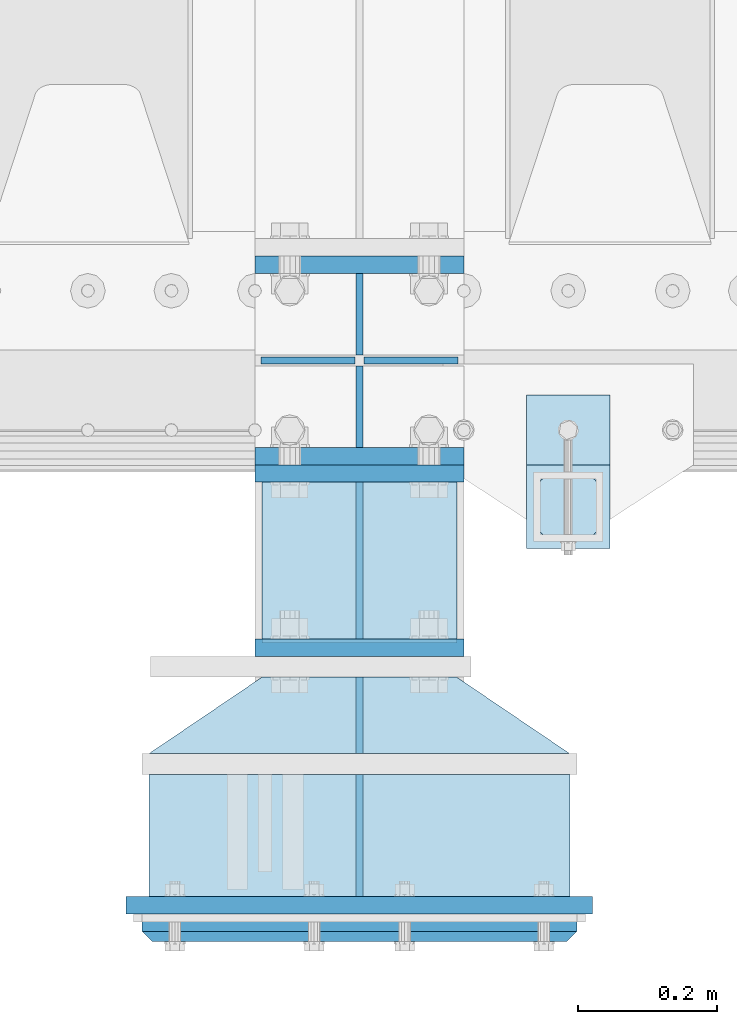
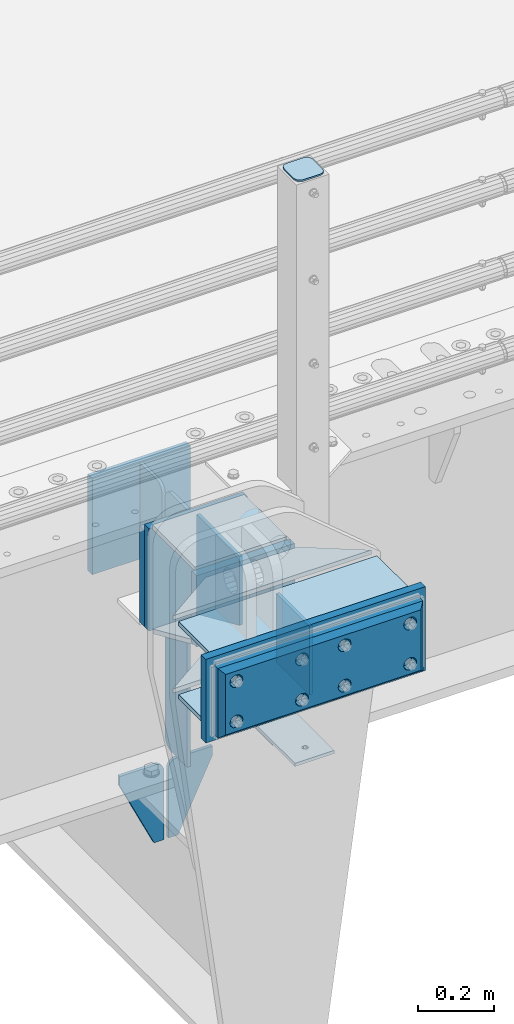
# One storey, part 182 of 219: 23 plates.
"""IFC2X3 building model written with IfcOpenShell, lengths in millimetres."""

from ifc_helpers import new_model, si_unit, frame, origin_with_axes, place, context, subcontext, project, spatial, faceted_brep, material, type_object, element, save


model = new_model("IFC2X3")

# Units and contexts
model_context = context("Model", 3, precision=1e-05, world=origin_with_axes())
body_context = subcontext(model_context, "Body", "Model", "MODEL_VIEW")
ifc_project = project(units=[si_unit("LENGTHUNIT", "METRE", prefix="MILLI"), si_unit("AREAUNIT", "SQUARE_METRE"), si_unit("VOLUMEUNIT", "CUBIC_METRE"), si_unit("MASSUNIT", "GRAM", prefix="KILO"), si_unit("TIMEUNIT", "SECOND"), si_unit("PLANEANGLEUNIT", "RADIAN"), si_unit("SOLIDANGLEUNIT", "STERADIAN"), si_unit("THERMODYNAMICTEMPERATUREUNIT", "DEGREE_CELSIUS"), si_unit("LUMINOUSINTENSITYUNIT", "LUMEN")], contexts=[model_context])

# Site, building, storey
site_placement = place(None, origin_with_axes())
site = spatial("IfcSite", under=ifc_project, at=site_placement, CompositionType="ELEMENT")
building_placement = place(site_placement, origin_with_axes())
building = spatial("IfcBuilding", under=site, at=building_placement, Name="Standard", CompositionType="ELEMENT")
storey_placement = place(building_placement, origin_with_axes())
storey = spatial("IfcBuildingStorey", under=building, at=storey_placement, Name="Undefined", CompositionType="ELEMENT", Elevation=0.0)

# Plates
ifc_material_1 = material(Name="STEEL/S355N")
plate_type_1 = type_object("IfcPlateType", PredefinedType="NOTDEFINED")
plate_1_placement = place(storey_placement, frame((10240.0000000204, 23837.500000015, -340.000018206199), z_axis=(0.0, 0.0, 1.0), x_axis=(1.0, 0.0, 0.0)))
element("IfcPlate", 1, at=plate_1_placement, inside=storey, type_object=plate_type_1, material=ifc_material_1, context=body_context, shape_type="Brep", body=[
    faceted_brep([(0.0, -12.5, 0.0), (0.0, -12.5, 330.0), (0.0, 12.5, 330.0), (0.0, 12.5, 0.0), (300.0, -12.5, 330.0), (300.0, 12.5, 330.0), (300.0, -12.5, 0.0), (300.0, 12.5, 0.0)], [[[0, 1, 2, 3]], [[1, 4, 5, 2]], [[4, 6, 7, 5]], [[6, 0, 3, 7]], [[5, 7, 3, 2]], [[6, 4, 1, 0]]]),
])
for number, where, z_axis, x_axis in (
    (2, (10240.0, 24137.5, -340.0), (0.0, 0.0, 1.0), (1.0, 0.0, 0.0)),
    (3, (10240.0, 23862.5, -340.0), (0.0, 0.0, 1.0), (1.0, 0.0, 0.0)),
):
    element("IfcPlate", number, at=place(storey_placement, frame(where, z_axis=z_axis, x_axis=x_axis)), inside=storey, type_object=plate_type_1, material=ifc_material_1, context=body_context, shape_type="Brep", body=[
        faceted_brep([(0.0, -12.5, 0.0), (0.0, -12.5, 310.0), (0.0, 12.5, 310.0), (0.0, 12.5, 0.0), (300.0, -12.5, 310.0), (300.0, 12.5, 310.0), (300.0, -12.5, 0.0), (300.0, 12.5, 0.0)], [[[0, 1, 2, 3]], [[1, 4, 5, 2]], [[4, 6, 7, 5]], [[6, 0, 3, 7]], [[5, 7, 3, 2]], [[6, 4, 1, 0]]]),
    ])
plate_type_2 = type_object("IfcPlateType", PredefinedType="NOTDEFINED")
plate_2_placement = place(storey_placement, frame((10390.0000000208, 23825.0000000149, -336.000018206199), z_axis=(0.0, -1.0, 0.0), x_axis=(0.0, 0.0, 1.0)))
element("IfcPlate", 4, at=plate_2_placement, inside=storey, type_object=plate_type_2, material=ifc_material_1, context=body_context, shape_type="Brep", body=[
    faceted_brep([(0.0, -5.0, 0.0), (100.0, -5.0, 225.0), (100.0, 5.0, 225.0), (0.0, 5.0, 0.0), (322.0, -5.0, 225.0), (322.0, 5.0, 225.0), (322.0, -5.0, 0.0), (322.0, 5.0, 0.0)], [[[0, 1, 2, 3]], [[1, 4, 5, 2]], [[4, 6, 7, 5]], [[6, 0, 3, 7]], [[5, 7, 3, 2]], [[6, 4, 1, 0]]]),
])
plate_type_3 = type_object("IfcPlateType", PredefinedType="NOTDEFINED")
for number, where, z_axis, x_axis in (
    (5, (10390.0, 24008.0, -30.0), (0.0, 0.0, -1.0), (0.0, 1.0, 0.0)),
    (6, (10390.0, 23992.0, -30.0), (0.0, 0.0, -1.0), (0.0, -1.0, 0.0)),
):
    element("IfcPlate", number, at=place(storey_placement, frame(where, z_axis=z_axis, x_axis=x_axis)), inside=storey, type_object=plate_type_3, material=ifc_material_1, context=body_context, shape_type="Brep", body=[
        faceted_brep([(0.0, -5.0, 30.0), (0.0, -5.0, 306.0), (0.0, 5.0, 306.0), (0.0, 5.0, 30.0), (117.0, -5.0, 306.0), (117.0, 5.0, 306.0), (117.0, -5.0, 0.0), (117.0, 5.0, 0.0), (30.0, -5.0, 0.0), (30.0, 5.0, 0.0), (24.7905546699913, -5.0, 0.455767409633758), (24.7905546699913, 5.0, 0.455767409633758), (19.7393957002278, -5.0, 1.80922137642275), (19.7393957002278, 5.0, 1.80922137642275), (15.0, -5.0, 4.01923788646684), (15.0, 5.0, 4.01923788646684), (10.7163717094008, -5.0, 7.01866670643066), (10.7163717094008, 5.0, 7.01866670643066), (7.01866670643358, -5.0, 10.7163717094038), (7.01866670643358, 5.0, 10.7163717094038), (4.01923788646673, -5.0, 15.0), (4.01923788646673, 5.0, 15.0), (1.80922137642483, -5.0, 19.7393957002299), (1.80922137642483, 5.0, 19.7393957002299), (0.455767409635882, -5.0, 24.7905546699921), (0.455767409635882, 5.0, 24.7905546699921)], [[[0, 1, 2, 3]], [[1, 4, 5, 2]], [[4, 6, 7, 5]], [[6, 8, 9, 7]], [[8, 10, 11, 9]], [[10, 12, 13, 11]], [[12, 14, 15, 13]], [[14, 16, 17, 15]], [[16, 18, 19, 17]], [[18, 20, 21, 19]], [[20, 22, 23, 21]], [[22, 24, 25, 23]], [[24, 0, 3, 25]], [[5, 7, 9, 11, 13, 15, 17, 19, 21, 23, 25, 3, 2]], [[24, 22, 20, 18, 16, 14, 12, 10, 8, 6, 4, 1, 0]]]),
    ])
plate_3_placement = place(storey_placement, frame((10390.0, 23992.0, -350.0), z_axis=(0.0, 0.0, -1.0), x_axis=(0.0, -1.0, 0.0)))
element("IfcPlate", 7, at=plate_3_placement, inside=storey, type_object=plate_type_3, material=ifc_material_1, context=body_context, shape_type="Brep", body=[
    faceted_brep([(0.0, -5.0, 0.0), (0.0, -5.0, 480.0), (0.0, 5.0, 480.0), (0.0, 5.0, 0.0), (0.455767409635882, -5.0, 485.209445330008), (0.455767409635882, 5.0, 485.209445330008), (1.80922137642483, -5.0, 490.26060429977), (1.80922137642483, 5.0, 490.26060429977), (4.01923788646673, -5.0, 495.0), (4.01923788646673, 5.0, 495.0), (7.01866670643358, -5.0, 499.283628290596), (7.01866670643358, 5.0, 499.283628290596), (10.7163717094008, -5.0, 502.981333293569), (10.7163717094008, 5.0, 502.981333293569), (15.0, -5.0, 505.980762113533), (15.0, 5.0, 505.980762113533), (19.7393957002278, -5.0, 508.190778623577), (19.7393957002278, 5.0, 508.190778623577), (24.7905546699913, -5.0, 509.544232590366), (24.7905546699913, 5.0, 509.544232590366), (30.0, -5.0, 510.0), (30.0, 5.0, 510.0), (117.0, -5.0, 510.0), (117.0, 5.0, 510.0), (117.0, -5.0, 0.0), (117.0, 5.0, 0.0)], [[[0, 1, 2, 3]], [[1, 4, 5, 2]], [[4, 6, 7, 5]], [[6, 8, 9, 7]], [[8, 10, 11, 9]], [[10, 12, 13, 11]], [[12, 14, 15, 13]], [[14, 16, 17, 15]], [[16, 18, 19, 17]], [[18, 20, 21, 19]], [[20, 22, 23, 21]], [[22, 24, 25, 23]], [[24, 0, 3, 25]], [[5, 7, 9, 11, 13, 15, 17, 19, 21, 23, 25, 3, 2]], [[24, 22, 20, 18, 16, 14, 12, 10, 8, 6, 4, 1, 0]]]),
])
plate_type_4 = type_object("IfcPlateType", PredefinedType="NOTDEFINED")
for number, where, z_axis, x_axis in (
    (8, (10383.5000000208, 24000.0000000149, -915.000018206197), (0.0, 0.0, -1.0), (-1.0, 0.0, 0.0)),
    (9, (10396.5000000208, 24000.0000000149, -915.000018206197), (0.0, 0.0, -1.0), (1.0, 0.0, 0.0)),
):
    element("IfcPlate", number, at=place(storey_placement, frame(where, z_axis=z_axis, x_axis=x_axis)), inside=storey, type_object=plate_type_4, material=ifc_material_1, context=body_context, shape_type="Brep", body=[
        faceted_brep([(0.0, -5.0, 27.0), (0.0, -5.0, 250.0), (0.0, 5.0, 250.0), (0.0, 5.0, 27.0), (30.0, -5.0, 250.0), (30.0, 5.0, 250.0), (135.0, -5.0, 30.0), (135.0, 5.0, 30.0), (135.0, -5.0, 0.0), (135.0, 5.0, 0.0), (27.0, -5.0, 0.0), (27.0, 5.0, 0.0), (22.3114992029932, -5.0, 0.410190668670339), (22.3114992029932, 5.0, 0.410190668670339), (17.7654561302061, -5.0, 1.62829923878041), (17.7654561302061, 5.0, 1.62829923878041), (13.5, -5.0, 3.61731409782021), (13.5, 5.0, 3.61731409782021), (9.64473453846404, -5.0, 6.31680003578765), (9.64473453846404, 5.0, 6.31680003578765), (6.31680003578731, -5.0, 9.64473453846347), (6.31680003578731, 5.0, 9.64473453846347), (3.61731409782078, -5.0, 13.5), (3.61731409782078, 5.0, 13.5), (1.62829923878053, -5.0, 17.765456130207), (1.62829923878053, 5.0, 17.765456130207), (0.410190668670111, -5.0, 22.3114992029929), (0.410190668670111, 5.0, 22.3114992029929)], [[[0, 1, 2, 3]], [[1, 4, 5, 2]], [[4, 6, 7, 5]], [[6, 8, 9, 7]], [[8, 10, 11, 9]], [[10, 12, 13, 11]], [[12, 14, 15, 13]], [[14, 16, 17, 15]], [[16, 18, 19, 17]], [[18, 20, 21, 19]], [[20, 22, 23, 21]], [[22, 24, 25, 23]], [[24, 26, 27, 25]], [[26, 0, 3, 27]], [[5, 7, 9, 11, 13, 15, 17, 19, 21, 23, 25, 27, 3, 2]], [[26, 24, 22, 20, 18, 16, 14, 12, 10, 8, 6, 4, 1, 0]]]),
    ])
ifc_material_2 = material(Name="STEEL/S355J2")
plate_type_5 = type_object("IfcPlateType", PredefinedType="NOTDEFINED")
plate_4_placement = place(storey_placement, frame((10749.9999999999, 23949.9999999998, -850.000000000002), z_axis=(0.0, -1.0, 0.0), x_axis=(-1.0, 0.0, 0.0)))
element("IfcPlate", 10, at=plate_4_placement, inside=storey, type_object=plate_type_5, material=ifc_material_2, context=body_context, shape_type="Brep", body=[
    faceted_brep([(53.6360389691836, -5.0, 176.363961030467), (53.6360389691836, 5.0, 176.363961030467), (59.9999999998618, 5.0, 178.999999999789), (59.9999999998618, -5.0, 178.999999999789), (66.3639610305399, 5.0, 176.363961030467), (66.3639610305399, -5.0, 176.363961030467), (68.9999999998618, 5.0, 169.999999999789), (68.9999999998618, -5.0, 169.999999999789), (66.3639610305399, 5.0, 163.636038969111), (66.3639610305399, -5.0, 163.636038969111), (59.9999999998618, 5.0, 160.999999999789), (59.9999999998618, -5.0, 160.999999999789), (53.6360389691836, 5.0, 163.636038969111), (53.6360389691836, -5.0, 163.636038969111), (50.9999999998618, 5.0, 169.999999999789), (50.9999999998618, -5.0, 169.999999999789), (120.0, -5.0, 0.0), (120.0, -5.0, 220.0), (0.0, -5.0, 220.0), (0.0, -5.0, 0.0), (0.0, 5.0, 0.0), (120.0, 5.0, 0.0), (120.0, 5.0, 220.0), (0.0, 5.0, 220.0)], [[[0, 1, 2, 3]], [[3, 2, 4, 5]], [[5, 4, 6, 7]], [[7, 6, 8, 9]], [[9, 8, 10, 11]], [[11, 10, 12, 13]], [[13, 12, 14, 15]], [[15, 14, 1, 0]], [[16, 17, 18, 19], [11, 13, 15, 0, 3, 5, 7, 9]], [[16, 19, 20, 21]], [[17, 16, 21, 22]], [[18, 17, 22, 23]], [[19, 18, 23, 20]], [[22, 21, 20, 23], [2, 1, 14, 12, 10, 8, 6, 4]]]),
])
plate_type_6 = type_object("IfcPlateType", PredefinedType="NOTDEFINED")
plate_5_placement = place(storey_placement, frame((10645.9999999999, 23833.9999999998, 1012.50000000001), z_axis=(0.0, -1.0, 0.0), x_axis=(1.0, 0.0, 0.0)))
element("IfcPlate", 11, at=plate_5_placement, inside=storey, type_object=plate_type_6, material=ifc_material_2, context=body_context, shape_type="Brep", body=[
    faceted_brep([(0.0, -2.5, 19.0), (0.0, -2.5, 69.0), (0.0, 2.5, 69.0), (0.0, 2.5, 19.0), (0.476369668545885, -2.5, 73.2278977451715), (0.476369668545885, 2.5, 73.2278977451715), (1.88159150985484, -2.5, 77.2437910432345), (1.88159150985484, 2.5, 77.2437910432345), (4.14520183310742, -2.5, 80.8463062353185), (4.14520183310742, 2.5, 80.8463062353185), (7.15369376468334, -2.5, 83.8547981668889), (7.15369376468334, 2.5, 83.8547981668889), (10.7562089567673, -2.5, 86.118408490147), (10.7562089567673, 2.5, 86.118408490147), (14.7721022548303, -2.5, 87.5236303314523), (14.7721022548303, 2.5, 87.5236303314523), (19.0, -2.5, 88.0), (19.0, 2.5, 88.0), (69.0, -2.5, 88.0), (69.0, 2.5, 88.0), (73.2278977451697, -2.5, 87.5236303314523), (73.2278977451697, 2.5, 87.5236303314523), (77.2437910432327, -2.5, 86.118408490147), (77.2437910432327, 2.5, 86.118408490147), (80.8463062353167, -2.5, 83.8547981668889), (80.8463062353167, 2.5, 83.8547981668889), (83.8547981668926, -2.5, 80.8463062353185), (83.8547981668926, 2.5, 80.8463062353185), (86.1184084901452, -2.5, 77.2437910432345), (86.1184084901452, 2.5, 77.2437910432345), (87.5236303314541, -2.5, 73.2278977451715), (87.5236303314541, 2.5, 73.2278977451715), (88.0, -2.5, 69.0), (88.0, 2.5, 69.0), (88.0, -2.5, 19.0), (88.0, 2.5, 19.0), (87.5236303314541, -2.5, 14.7721022548285), (87.5236303314541, 2.5, 14.7721022548285), (86.1184084901452, -2.5, 10.7562089567655), (86.1184084901452, 2.5, 10.7562089567655), (83.8547981668926, -2.5, 7.15369376468152), (83.8547981668926, 2.5, 7.15369376468152), (80.8463062353167, -2.5, 4.14520183311106), (80.8463062353167, 2.5, 4.14520183311106), (77.2437910432345, -2.5, 1.88159150985302), (77.2437910432345, 2.5, 1.88159150985302), (73.2278977451697, -2.5, 0.476369668547704), (73.2278977451697, 2.5, 0.476369668547704), (69.0, -2.5, 0.0), (69.0, 2.5, 0.0), (19.0, -2.5, 0.0), (19.0, 2.5, 0.0), (14.7721022548303, -2.5, 0.476369668547704), (14.7721022548303, 2.5, 0.476369668547704), (10.7562089567673, -2.5, 1.88159150985302), (10.7562089567673, 2.5, 1.88159150985302), (7.15369376468334, -2.5, 4.14520183311106), (7.15369376468334, 2.5, 4.14520183311106), (4.14520183310742, -2.5, 7.15369376468152), (4.14520183310742, 2.5, 7.15369376468152), (1.88159150985484, -2.5, 10.7562089567655), (1.88159150985484, 2.5, 10.7562089567655), (0.476369668545885, -2.5, 14.7721022548285), (0.476369668545885, 2.5, 14.7721022548285)], [[[0, 1, 2, 3]], [[1, 4, 5, 2]], [[4, 6, 7, 5]], [[6, 8, 9, 7]], [[8, 10, 11, 9]], [[10, 12, 13, 11]], [[12, 14, 15, 13]], [[14, 16, 17, 15]], [[16, 18, 19, 17]], [[18, 20, 21, 19]], [[20, 22, 23, 21]], [[22, 24, 25, 23]], [[24, 26, 27, 25]], [[26, 28, 29, 27]], [[28, 30, 31, 29]], [[30, 32, 33, 31]], [[32, 34, 35, 33]], [[34, 36, 37, 35]], [[36, 38, 39, 37]], [[38, 40, 41, 39]], [[40, 42, 43, 41]], [[42, 44, 45, 43]], [[44, 46, 47, 45]], [[46, 48, 49, 47]], [[48, 50, 51, 49]], [[50, 52, 53, 51]], [[52, 54, 55, 53]], [[54, 56, 57, 55]], [[56, 58, 59, 57]], [[58, 60, 61, 59]], [[60, 62, 63, 61]], [[62, 0, 3, 63]], [[5, 7, 9, 11, 13, 15, 17, 19, 21, 23, 25, 27, 29, 31, 33, 35, 37, 39, 41, 43, 45, 47, 49, 51, 53, 55, 57, 59, 61, 63, 3, 2]], [[62, 60, 58, 56, 54, 52, 50, 48, 46, 44, 42, 40, 38, 36, 34, 32, 30, 28, 26, 24, 22, 20, 18, 16, 14, 12, 10, 8, 6, 4, 1, 0]]]),
])
plate_type_7 = type_object("IfcPlateType", PredefinedType="NOTDEFINED")
plate_6_placement = place(storey_placement, frame((10749.9999999999, 23949.9999999998, -857.500000000002), z_axis=(0.0, -1.0, 0.0), x_axis=(-1.0, 0.0, 0.0)))
element("IfcPlate", 12, at=plate_6_placement, inside=storey, type_object=plate_type_7, material=ifc_material_2, context=body_context, shape_type="Brep", body=[
    faceted_brep([(0.0, -2.5, 0.0), (0.0, -2.5, 100.0), (0.0, 2.5, 100.0), (0.0, 2.5, 0.0), (120.0, -2.5, 100.0), (120.0, 2.5, 100.0), (120.0, -2.5, 0.0), (120.0, 2.5, 0.0)], [[[0, 1, 2, 3]], [[1, 4, 5, 2]], [[4, 6, 7, 5]], [[6, 0, 3, 7]], [[5, 7, 3, 2]], [[6, 4, 1, 0]]]),
])
plate_type_8 = type_object("IfcPlateType", PredefinedType="NOTDEFINED")
plate_7_placement = place(storey_placement, frame((10390.000000021, 23230.0000000149, -14.0000182061987), z_axis=(0.0, 0.0, -1.0), x_axis=(0.0, 1.0, 0.0)))
element("IfcPlate", 13, at=plate_7_placement, inside=storey, type_object=plate_type_8, material=ifc_material_1, context=body_context, shape_type="Brep", body=[
    faceted_brep([(0.0, -5.0, 0.0), (0.0, -5.0, 222.0), (0.0, 5.0, 222.0), (0.0, 5.0, 0.0), (175.0, -5.0, 222.0), (175.0, 5.0, 222.0), (175.0, -5.0, 0.0), (175.0, 5.0, 0.0)], [[[0, 1, 2, 3]], [[1, 4, 5, 2]], [[4, 6, 7, 5]], [[6, 0, 3, 7]], [[5, 7, 3, 2]], [[6, 4, 1, 0]]]),
])
plate_type_9 = type_object("IfcPlateType", PredefinedType="NOTDEFINED")
plate_8_placement = place(storey_placement, frame((10390.000000021, 23435.0000000149, -14.0000182061987), z_axis=(0.0, 0.0, -1.0), x_axis=(0.0, 1.0, 0.0)))
element("IfcPlate", 14, at=plate_8_placement, inside=storey, type_object=plate_type_9, material=ifc_material_1, context=body_context, shape_type="Brep", body=[
    faceted_brep([(0.0, -5.0, 0.0), (0.0, -5.0, 222.0), (0.0, 5.0, 222.0), (0.0, 5.0, 0.0), (110.0, -5.0, 222.0), (110.0, 5.0, 222.0), (110.0, -5.0, 0.0), (110.0, 5.0, 0.0)], [[[0, 1, 2, 3]], [[1, 4, 5, 2]], [[4, 6, 7, 5]], [[6, 0, 3, 7]], [[5, 7, 3, 2]], [[6, 4, 1, 0]]]),
])
ifc_material_3 = material()
plate_type_10 = type_object("IfcPlateType", PredefinedType="NOTDEFINED")
for number, where, z_axis, x_axis in (
    (15, (10692.5000000218, 23405.0000000148, -7.00001820619866), (0.0, -1.0, 0.0), (-1.0, 0.0, 0.0)),
    (16, (10692.5000000218, 23405.0000000148, -243.000018206199), (0.0, -1.0, 0.0), (-1.0, 0.0, 0.0)),
):
    element("IfcPlate", number, at=place(storey_placement, frame(where, z_axis=z_axis, x_axis=x_axis)), inside=storey, type_object=plate_type_10, material=ifc_material_3, context=body_context, shape_type="Brep", body=[
        faceted_brep([(0.0, -7.0, 0.0), (0.0, -7.0, 175.0), (0.0, 7.0, 175.0), (0.0, 7.0, 0.0), (605.0, -7.0, 175.0), (605.0, 7.0, 175.0), (605.0, -7.0, 0.0), (605.0, 7.0, 0.0)], [[[0, 1, 2, 3]], [[1, 4, 5, 2]], [[4, 6, 7, 5]], [[6, 0, 3, 7]], [[5, 7, 3, 2]], [[6, 4, 1, 0]]]),
    ])
plate_type_11 = type_object("IfcPlateType", PredefinedType="NOTDEFINED")
for number, where, z_axis, x_axis in (
    (17, (10692.5000000218, 23435.0000000148, -243.000018206199), (-0.560566412034006, -0.828109472050236, 0.0), (-0.828109472050235, 0.560566412034008, 0.0)),
    (18, (10692.5000000218, 23435.0000000148, -7.00001820619866), (-0.560566412034006, -0.828109472050236, 0.0), (-0.828109472050235, 0.560566412034008, 0.0)),
):
    element("IfcPlate", number, at=place(storey_placement, frame(where, z_axis=z_axis, x_axis=x_axis)), inside=storey, type_object=plate_type_11, material=ifc_material_1, context=body_context, shape_type="Brep", body=[
        faceted_brep([(0.0, -7.0, 0.0), (501.006225585941, -7.0, 339.142669677731), (501.006225585941, 7.0, 339.142669677731), (0.0, 7.0, 0.0), (428.100738525394, -7.0, 156.95860290527), (428.100738525394, 7.0, 156.95860290527), (196.230087280277, -7.0, 2.58296495303512e-10), (196.230087280277, 7.0, 2.58296495303512e-10)], [[[0, 1, 2, 3]], [[1, 4, 5, 2]], [[4, 6, 7, 5]], [[6, 0, 3, 7]], [[5, 7, 3, 2]], [[6, 4, 1, 0]]]),
    ])
plate_type_12 = type_object("IfcPlateType", PredefinedType="NOTDEFINED")
plate_9_placement = place(storey_placement, frame((10725.0000000219, 23217.5000000148, 9.99998179380134), z_axis=(0.0, 0.0, -1.0), x_axis=(-1.0, 0.0, 0.0)))
element("IfcPlate", 19, at=plate_9_placement, inside=storey, type_object=plate_type_12, material=ifc_material_1, context=body_context, shape_type="Brep", body=[
    faceted_brep([(0.0, -12.5, 0.0), (0.0, -12.5, 270.0), (0.0, 12.5, 270.0), (0.0, 12.5, 0.0), (670.0, -12.5, 270.0), (670.0, 12.5, 270.0), (670.0, -12.5, 0.0), (670.0, 12.5, 0.0)], [[[0, 1, 2, 3]], [[1, 4, 5, 2]], [[4, 6, 7, 5]], [[6, 0, 3, 7]], [[5, 7, 3, 2]], [[6, 4, 1, 0]]]),
])
plate_type_13 = type_object("IfcPlateType", PredefinedType="NOTDEFINED")
plate_10_placement = place(storey_placement, frame((10240.0000000205, 23587.500000015, -240.000018206199), z_axis=(0.0, 0.0, 1.0), x_axis=(1.0, 0.0, 0.0)))
element("IfcPlate", 20, at=plate_10_placement, inside=storey, type_object=plate_type_13, material=ifc_material_1, context=body_context, shape_type="Brep", body=[
    faceted_brep([(0.0, -12.5, 0.0), (0.0, -12.5, 230.0), (0.0, 12.5, 230.0), (0.0, 12.5, 0.0), (300.0, -12.5, 230.0), (300.0, 12.5, 230.0), (300.0, -12.5, 0.0), (300.0, 12.5, 0.0)], [[[0, 1, 2, 3]], [[1, 4, 5, 2]], [[4, 6, 7, 5]], [[6, 0, 3, 7]], [[5, 7, 3, 2]], [[6, 4, 1, 0]]]),
])
ifc_material_4 = material()
plate_type_14 = type_object("IfcPlateType", PredefinedType="NOTDEFINED")
plate_11_placement = place(storey_placement, frame((10702.5000000219, 23185.0000000148, -12.5000182061987), z_axis=(0.0, 0.0, -1.0), x_axis=(-1.0, 0.0, 0.0)))
element("IfcPlate", 21, at=plate_11_placement, inside=storey, type_object=plate_type_14, material=ifc_material_4, context=body_context, shape_type="Brep", body=[
    faceted_brep([(0.0, -5.0, 0.0), (15.0, -20.0, 15.0), (15.0, -20.0, 210.0), (0.0, -5.0, 225.0), (625.0, -5.0, 225.0), (610.0, -20.0, 210.0), (610.0, -20.0, 15.0), (625.0, -5.0, 0.0), (625.0, 15.0, 0.0), (620.0, 20.0, 5.0), (620.0, 20.0, 220.0), (625.0, 15.0, 225.0), (0.0, 15.0, 225.0), (5.0, 20.0, 220.0), (5.0, 20.0, 5.0), (0.0, 15.0, 0.0), (30.1794919244185, 5.00000000001455, 37.4999999999982), (37.5000000001073, 5.00000000001455, 30.1794919243094), (47.5000000001073, 5.00000000001455, 27.4999999999982), (57.5000000001073, 5.00000000001455, 30.1794919243094), (64.8205080757962, 5.00000000001455, 37.4999999999982), (67.5000000001073, 5.00000000001455, 47.4999999999982), (64.8205080757962, 5.00000000001455, 57.4999999999982), (57.5000000001073, 5.00000000001455, 64.8205080756869), (47.5000000001073, 5.00000000001455, 67.4999999999982), (37.5000000001073, 5.00000000001455, 64.820508075687), (30.1794919244185, 5.00000000001455, 57.4999999999982), (27.5000000001073, 5.00000000001455, 47.4999999999982), (37.5000000001073, -20.0, 30.1794919243094), (30.1794919244185, -20.0, 37.4999999999982), (47.5000000001073, -20.0, 27.4999999999982), (57.5000000001073, -20.0, 30.1794919243094), (64.8205080757962, -20.0, 37.4999999999982), (67.5000000001073, -20.0, 47.4999999999982), (64.8205080757962, -20.0, 57.4999999999982), (57.5000000001073, -20.0, 64.8205080756869), (47.5000000001073, -20.0, 67.4999999999982), (37.5000000001073, -20.0, 64.820508075687), (30.1794919244185, -20.0, 57.4999999999982), (27.5000000001073, -20.0, 47.4999999999982), (360.179491925306, 5.00000000012005, 37.4999999999982), (367.500000000995, 5.00000000012005, 30.1794919243094), (377.500000000995, 5.00000000012005, 27.4999999999982), (387.500000000995, 5.00000000012005, 30.1794919243094), (394.820508076684, 5.00000000012005, 37.4999999999982), (397.500000000995, 5.00000000012005, 47.4999999999982), (394.820508076684, 5.00000000012005, 57.4999999999982), (387.500000000995, 5.00000000012005, 64.8205080756869), (377.500000000995, 5.00000000012005, 67.4999999999982), (367.500000000995, 5.00000000012005, 64.820508075687), (360.179491925306, 5.00000000012005, 57.4999999999982), (357.500000000995, 5.00000000012005, 47.4999999999982), (360.179491925306, -20.0, 37.4999999999982), (357.500000000995, -20.0, 47.4999999999982), (367.500000000995, -20.0, 30.1794919243094), (377.500000000995, -20.0, 27.4999999999982), (387.500000000995, -20.0, 30.1794919243094), (394.820508076684, -20.0, 37.4999999999982), (397.500000000995, -20.0, 47.4999999999982), (394.820508076684, -20.0, 57.4999999999982), (387.500000000995, -20.0, 64.8205080756869), (377.500000000995, -20.0, 67.4999999999982), (367.500000000995, -20.0, 64.820508075687), (360.179491925306, -20.0, 57.4999999999982), (360.179491925306, 5.00000000012005, 167.499999999998), (367.500000000995, 5.00000000012005, 160.179491924309), (377.500000000995, 5.00000000012005, 157.499999999998), (387.500000000995, 5.00000000012005, 160.179491924309), (394.820508076684, 5.00000000012005, 167.499999999998), (397.500000000995, 5.00000000012005, 177.499999999998), (394.820508076684, 5.00000000012005, 187.499999999998), (387.500000000995, 5.00000000012005, 194.820508075687), (377.500000000995, 5.00000000012005, 197.499999999998), (367.500000000995, 5.00000000012005, 194.820508075687), (360.179491925306, 5.00000000012005, 187.499999999998), (357.500000000995, 5.00000000012005, 177.499999999998), (360.179491925306, -20.0, 167.499999999998), (357.500000000995, -20.0, 177.499999999998), (367.500000000995, -20.0, 160.179491924309), (377.500000000995, -20.0, 157.499999999998), (387.500000000995, -20.0, 160.179491924309), (394.820508076684, -20.0, 167.499999999998), (397.500000000995, -20.0, 177.499999999998), (394.820508076684, -20.0, 187.499999999998), (387.500000000995, -20.0, 194.820508075687), (377.500000000995, -20.0, 197.499999999998), (367.500000000995, -20.0, 194.820508075687), (360.179491925306, -20.0, 187.499999999998), (560.179491925845, 5.0000000001819, 167.499999999998), (567.500000001533, 5.0000000001819, 160.179491924309), (577.500000001533, 5.0000000001819, 157.499999999998), (587.500000001533, 5.0000000001819, 160.179491924309), (594.820508077222, 5.0000000001819, 167.499999999998), (597.500000001533, 5.0000000001819, 177.499999999998), (594.820508077222, 5.0000000001819, 187.499999999998), (587.500000001533, 5.0000000001819, 194.820508075687), (577.500000001533, 5.0000000001819, 197.499999999998), (567.500000001533, 5.0000000001819, 194.820508075687), (560.179491925845, 5.0000000001819, 187.499999999998), (557.500000001533, 5.0000000001819, 177.499999999998), (560.179491925845, -20.0, 167.499999999998), (557.500000001533, -20.0, 177.499999999998), (567.500000001533, -20.0, 160.179491924309), (577.500000001533, -20.0, 157.499999999998), (587.500000001533, -20.0, 160.179491924309), (594.820508077222, -20.0, 167.499999999998), (597.500000001533, -20.0, 177.499999999998), (594.820508077222, -20.0, 187.499999999998), (587.500000001533, -20.0, 194.820508075687), (577.500000001533, -20.0, 197.499999999998), (567.500000001533, -20.0, 194.820508075687), (560.179491925845, -20.0, 187.499999999998), (230.179491924957, 5.0000000000764, 37.4999999999982), (237.500000000646, 5.0000000000764, 30.1794919243094), (247.500000000646, 5.0000000000764, 27.4999999999982), (257.500000000646, 5.0000000000764, 30.1794919243094), (264.820508076335, 5.0000000000764, 37.4999999999982), (267.500000000646, 5.0000000000764, 47.4999999999982), (264.820508076335, 5.0000000000764, 57.4999999999982), (257.500000000646, 5.0000000000764, 64.8205080756869), (247.500000000646, 5.0000000000764, 67.4999999999982), (237.500000000646, 5.0000000000764, 64.820508075687), (230.179491924957, 5.0000000000764, 57.4999999999982), (227.500000000646, 5.0000000000764, 47.4999999999982), (230.179491924957, -20.0, 37.4999999999982), (227.500000000646, -20.0, 47.4999999999982), (237.500000000646, -20.0, 30.1794919243094), (247.500000000646, -20.0, 27.4999999999982), (257.500000000646, -20.0, 30.1794919243094), (264.820508076335, -20.0, 37.4999999999982), (267.500000000646, -20.0, 47.4999999999982), (264.820508076335, -20.0, 57.4999999999982), (257.500000000646, -20.0, 64.8205080756869), (247.500000000646, -20.0, 67.4999999999982), (237.500000000646, -20.0, 64.820508075687), (230.179491924957, -20.0, 57.4999999999982), (30.1794919244185, 5.00000000001455, 167.499999999998), (37.5000000001073, 5.00000000001455, 160.179491924309), (47.5000000001073, 5.00000000001455, 157.499999999998), (57.5000000001073, 5.00000000001455, 160.179491924309), (64.8205080757962, 5.00000000001455, 167.499999999998), (67.5000000001073, 5.00000000001455, 177.499999999998), (64.8205080757962, 5.00000000001455, 187.499999999998), (57.5000000001073, 5.00000000001455, 194.820508075687), (47.5000000001073, 5.00000000001455, 197.499999999998), (37.5000000001073, 5.00000000001455, 194.820508075687), (30.1794919244185, 5.00000000001455, 187.499999999998), (27.5000000001073, 5.00000000001455, 177.499999999998), (30.1794919244185, -20.0, 167.499999999998), (27.5000000001073, -20.0, 177.499999999998), (37.5000000001073, -20.0, 160.179491924309), (47.5000000001073, -20.0, 157.499999999998), (57.5000000001073, -20.0, 160.179491924309), (64.8205080757962, -20.0, 167.499999999998), (67.5000000001073, -20.0, 177.499999999998), (64.8205080757962, -20.0, 187.499999999998), (57.5000000001073, -20.0, 194.820508075687), (47.5000000001073, -20.0, 197.499999999998), (37.5000000001073, -20.0, 194.820508075687), (30.1794919244185, -20.0, 187.499999999998), (230.179491924957, 5.0000000000764, 167.499999999998), (237.500000000646, 5.0000000000764, 160.179491924309), (247.500000000646, 5.0000000000764, 157.499999999998), (257.500000000646, 5.0000000000764, 160.179491924309), (264.820508076335, 5.0000000000764, 167.499999999998), (267.500000000646, 5.0000000000764, 177.499999999998), (264.820508076335, 5.0000000000764, 187.499999999998), (257.500000000646, 5.0000000000764, 194.820508075687), (247.500000000646, 5.0000000000764, 197.499999999998), (237.500000000646, 5.0000000000764, 194.820508075687), (230.179491924957, 5.0000000000764, 187.499999999998), (227.500000000646, 5.0000000000764, 177.499999999998), (230.179491924957, -20.0, 167.499999999998), (227.500000000646, -20.0, 177.499999999998), (237.500000000646, -20.0, 160.179491924309), (247.500000000646, -20.0, 157.499999999998), (257.500000000646, -20.0, 160.179491924309), (264.820508076335, -20.0, 167.499999999998), (267.500000000646, -20.0, 177.499999999998), (264.820508076335, -20.0, 187.499999999998), (257.500000000646, -20.0, 194.820508075687), (247.500000000646, -20.0, 197.499999999998), (237.500000000646, -20.0, 194.820508075687), (230.179491924957, -20.0, 187.499999999998), (560.179491925845, 5.0000000001819, 37.4999999999982), (567.500000001533, 5.0000000001819, 30.1794919243094), (577.500000001533, 5.0000000001819, 27.4999999999982), (587.500000001533, 5.0000000001819, 30.1794919243094), (594.820508077222, 5.0000000001819, 37.4999999999982), (597.500000001533, 5.0000000001819, 47.4999999999982), (594.820508077222, 5.0000000001819, 57.4999999999982), (587.500000001533, 5.0000000001819, 64.8205080756869), (577.500000001533, 5.0000000001819, 67.4999999999982), (567.500000001533, 5.0000000001819, 64.820508075687), (560.179491925845, 5.0000000001819, 57.4999999999982), (557.500000001533, 5.0000000001819, 47.4999999999982), (560.179491925845, -20.0, 37.4999999999982), (557.500000001533, -20.0, 47.4999999999982), (567.500000001533, -20.0, 30.1794919243094), (577.500000001533, -20.0, 27.4999999999982), (587.500000001533, -20.0, 30.1794919243094), (594.820508077222, -20.0, 37.4999999999982), (597.500000001533, -20.0, 47.4999999999982), (594.820508077222, -20.0, 57.4999999999982), (587.500000001533, -20.0, 64.8205080756869), (577.500000001533, -20.0, 67.4999999999982), (567.500000001533, -20.0, 64.820508075687), (560.179491925845, -20.0, 57.4999999999982)], [[[0, 1, 2, 3]], [[4, 5, 6, 7]], [[8, 9, 10, 11]], [[12, 13, 14, 15]], [[15, 14, 9, 8]], [[5, 4, 3, 2]], [[13, 12, 11, 10]], [[7, 6, 1, 0]], [[16, 17, 18, 19, 20, 21, 22, 23, 24, 25, 26, 27]], [[28, 17, 16, 29]], [[30, 18, 17, 28]], [[31, 19, 18, 30]], [[32, 20, 19, 31]], [[33, 21, 20, 32]], [[34, 22, 21, 33]], [[35, 23, 22, 34]], [[36, 24, 23, 35]], [[37, 25, 24, 36]], [[38, 26, 25, 37]], [[39, 27, 26, 38]], [[29, 16, 27, 39]], [[11, 12, 3, 4]], [[8, 11, 4, 7]], [[7, 0, 15, 8]], [[14, 13, 10, 9]], [[12, 15, 0, 3]], [[40, 41, 42, 43, 44, 45, 46, 47, 48, 49, 50, 51]], [[52, 40, 51, 53]], [[54, 41, 40, 52]], [[55, 42, 41, 54]], [[56, 43, 42, 55]], [[57, 44, 43, 56]], [[58, 45, 44, 57]], [[59, 46, 45, 58]], [[60, 47, 46, 59]], [[61, 48, 47, 60]], [[62, 49, 48, 61]], [[63, 50, 49, 62]], [[53, 51, 50, 63]], [[64, 65, 66, 67, 68, 69, 70, 71, 72, 73, 74, 75]], [[76, 64, 75, 77]], [[78, 65, 64, 76]], [[79, 66, 65, 78]], [[80, 67, 66, 79]], [[81, 68, 67, 80]], [[82, 69, 68, 81]], [[83, 70, 69, 82]], [[84, 71, 70, 83]], [[85, 72, 71, 84]], [[86, 73, 72, 85]], [[87, 74, 73, 86]], [[77, 75, 74, 87]], [[88, 89, 90, 91, 92, 93, 94, 95, 96, 97, 98, 99]], [[100, 88, 99, 101]], [[102, 89, 88, 100]], [[103, 90, 89, 102]], [[104, 91, 90, 103]], [[105, 92, 91, 104]], [[106, 93, 92, 105]], [[107, 94, 93, 106]], [[108, 95, 94, 107]], [[109, 96, 95, 108]], [[110, 97, 96, 109]], [[111, 98, 97, 110]], [[101, 99, 98, 111]], [[112, 113, 114, 115, 116, 117, 118, 119, 120, 121, 122, 123]], [[124, 112, 123, 125]], [[126, 113, 112, 124]], [[127, 114, 113, 126]], [[128, 115, 114, 127]], [[129, 116, 115, 128]], [[130, 117, 116, 129]], [[131, 118, 117, 130]], [[132, 119, 118, 131]], [[133, 120, 119, 132]], [[134, 121, 120, 133]], [[135, 122, 121, 134]], [[125, 123, 122, 135]], [[136, 137, 138, 139, 140, 141, 142, 143, 144, 145, 146, 147]], [[148, 136, 147, 149]], [[150, 137, 136, 148]], [[151, 138, 137, 150]], [[152, 139, 138, 151]], [[153, 140, 139, 152]], [[154, 141, 140, 153]], [[155, 142, 141, 154]], [[156, 143, 142, 155]], [[157, 144, 143, 156]], [[158, 145, 144, 157]], [[159, 146, 145, 158]], [[149, 147, 146, 159]], [[160, 161, 162, 163, 164, 165, 166, 167, 168, 169, 170, 171]], [[172, 160, 171, 173]], [[174, 161, 160, 172]], [[175, 162, 161, 174]], [[176, 163, 162, 175]], [[177, 164, 163, 176]], [[178, 165, 164, 177]], [[179, 166, 165, 178]], [[180, 167, 166, 179]], [[181, 168, 167, 180]], [[182, 169, 168, 181]], [[183, 170, 169, 182]], [[173, 171, 170, 183]], [[184, 185, 186, 187, 188, 189, 190, 191, 192, 193, 194, 195]], [[196, 184, 195, 197]], [[198, 185, 184, 196]], [[199, 186, 185, 198]], [[200, 187, 186, 199]], [[201, 188, 187, 200]], [[202, 189, 188, 201]], [[203, 190, 189, 202]], [[204, 191, 190, 203]], [[205, 192, 191, 204]], [[206, 193, 192, 205]], [[207, 194, 193, 206]], [[197, 195, 194, 207]], [[6, 5, 2, 1], [37, 36, 35, 34, 33, 32, 31, 30, 28, 29, 39, 38], [206, 205, 204, 203, 202, 201, 200, 199, 198, 196, 197, 207], [182, 181, 180, 179, 178, 177, 176, 175, 174, 172, 173, 183], [158, 157, 156, 155, 154, 153, 152, 151, 150, 148, 149, 159], [134, 133, 132, 131, 130, 129, 128, 127, 126, 124, 125, 135], [110, 109, 108, 107, 106, 105, 104, 103, 102, 100, 101, 111], [86, 85, 84, 83, 82, 81, 80, 79, 78, 76, 77, 87], [62, 61, 60, 59, 58, 57, 56, 55, 54, 52, 53, 63]]]),
])
plate_type_15 = type_object("IfcPlateType", PredefinedType="NOTDEFINED")
plate_12_placement = place(storey_placement, frame((10250.0000000205, 23825.000000015, -7.00001820619866), z_axis=(0.0, -1.0, 0.0), x_axis=(1.0, 0.0, 0.0)))
element("IfcPlate", 22, at=plate_12_placement, inside=storey, type_object=plate_type_15, material=ifc_material_1, context=body_context, shape_type="Brep", body=[
    faceted_brep([(0.0, -7.0, 0.0), (0.0, -7.0, 225.0), (0.0, 7.0, 225.0), (0.0, 7.0, 0.0), (280.0, -7.0, 225.0), (280.0, 7.0, 225.0), (280.0, -7.0, 0.0), (280.0, 7.0, 0.0)], [[[0, 1, 2, 3]], [[1, 4, 5, 2]], [[4, 6, 7, 5]], [[6, 0, 3, 7]], [[5, 7, 3, 2]], [[6, 4, 1, 0]]]),
])
plate_type_16 = type_object("IfcPlateType", PredefinedType="NOTDEFINED")
plate_13_placement = place(storey_placement, frame((10250.0000000205, 23822.1570307539, -342.396699047122), z_axis=(0.0, -0.913811548702731, 0.406138465867881), x_axis=(1.0, 0.0, 0.0)))
element("IfcPlate", 23, at=plate_13_placement, inside=storey, type_object=plate_type_16, material=ifc_material_1, context=body_context, shape_type="Brep", body=[
    faceted_brep([(0.0, -7.0, 0.0), (0.0, -6.99999999999818, 246.221450805664), (0.0, 7.0, 246.221450805664), (0.0, 7.0, 0.0), (280.0, -6.99999999999818, 246.221450805664), (280.0, 7.0, 246.221450805664), (280.0, -7.0, 0.0), (280.0, 7.0, 0.0)], [[[0, 1, 2, 3]], [[1, 4, 5, 2]], [[4, 6, 7, 5]], [[6, 0, 3, 7]], [[5, 7, 3, 2]], [[6, 4, 1, 0]]]),
])

save(model, "model.ifc")
